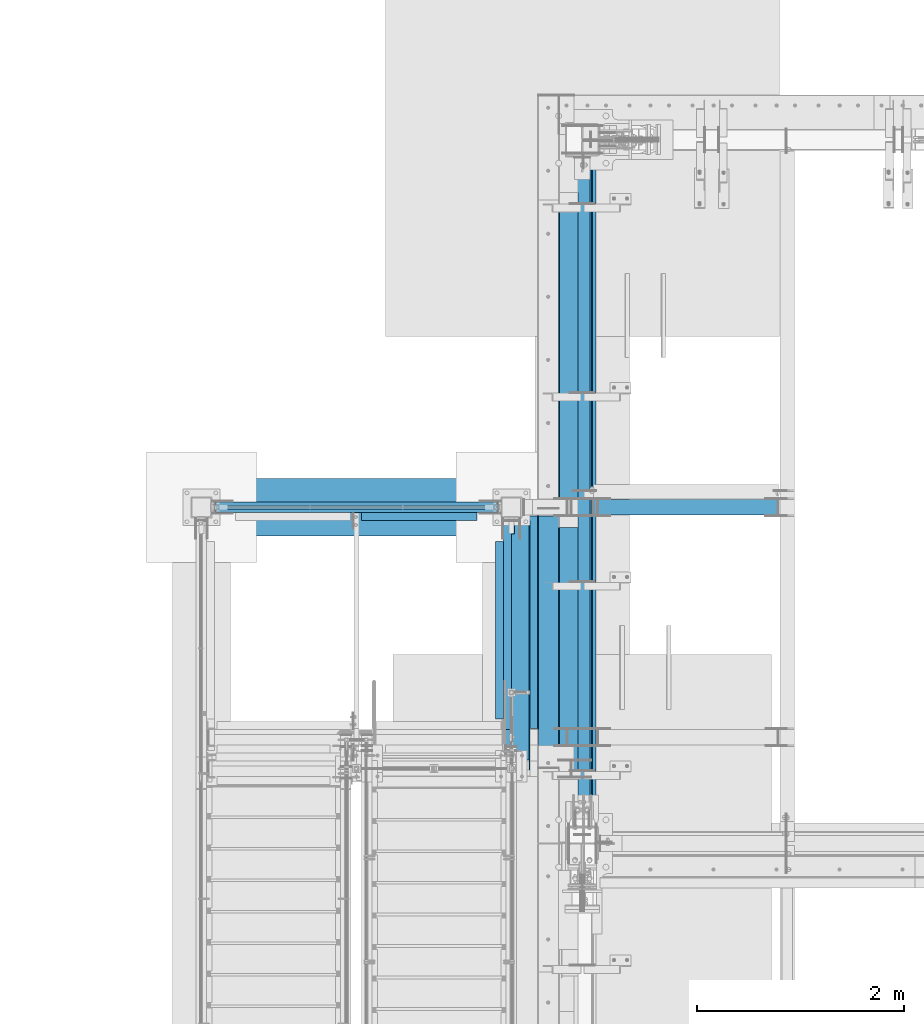
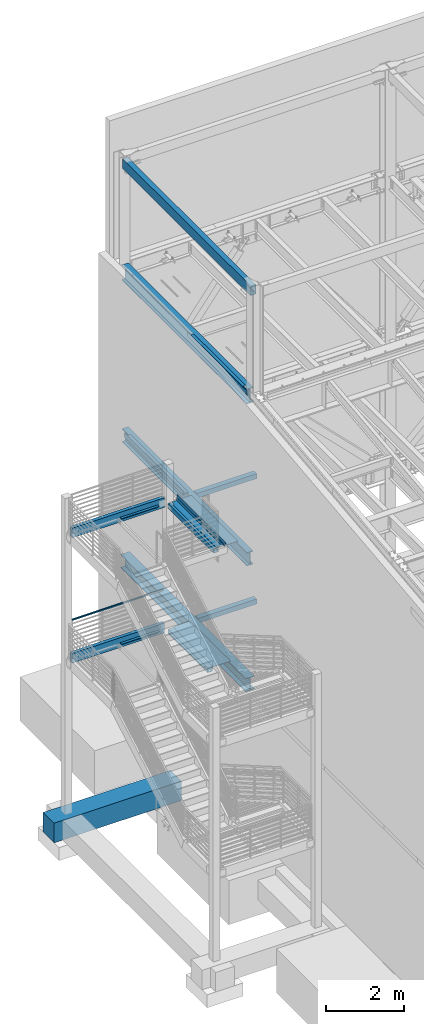
# One storey, part 765 of 1179: 20 beams, 12 elements without a shape of their own.
"""IFC2X3 building model written with IfcOpenShell, lengths in millimetres."""

from ifc_helpers import new_model, si_unit, frame, origin_with_axes, place, context, subcontext, project, spatial, faceted_brep, material, type_object, element, aggregate, save


model = new_model("IFC2X3")

# Units and contexts
model_context = context("Model", 3, precision=1e-05, world=origin_with_axes())
body_context = subcontext(model_context, "Body", "Model", "MODEL_VIEW")
ifc_project = project(units=[si_unit("LENGTHUNIT", "METRE", prefix="MILLI"), si_unit("AREAUNIT", "SQUARE_METRE"), si_unit("VOLUMEUNIT", "CUBIC_METRE"), si_unit("MASSUNIT", "GRAM", prefix="KILO"), si_unit("TIMEUNIT", "SECOND"), si_unit("PLANEANGLEUNIT", "RADIAN"), si_unit("SOLIDANGLEUNIT", "STERADIAN"), si_unit("THERMODYNAMICTEMPERATUREUNIT", "DEGREE_CELSIUS"), si_unit("LUMINOUSINTENSITYUNIT", "LUMEN")], contexts=[model_context])

# Site, building, storey
site_placement = place(None, origin_with_axes())
site = spatial("IfcSite", under=ifc_project, at=site_placement, CompositionType="ELEMENT")
building_placement = place(site_placement, origin_with_axes())
building = spatial("IfcBuilding", under=site, at=building_placement, Name="Undefined", CompositionType="ELEMENT")
storey_placement = place(building_placement, origin_with_axes())
storey = spatial("IfcBuildingStorey", under=building, at=storey_placement, Name="Undefined", CompositionType="ELEMENT", Elevation=0.0)

# Assembly, beam
assembly_1_placement = place(storey_placement, origin_with_axes())
assembly_1 = element("IfcElementAssembly", 1, at=assembly_1_placement, inside=storey, Name="GUARDRAIL", AssemblyPlace="NOTDEFINED", PredefinedType="RIGID_FRAME")
ifc_material_1 = material()
beam_type_1 = type_object("IfcBeamType", Name="HSS1-1/2X1-1/2X1/4", PredefinedType="NOTDEFINED")
beam_1_placement = place(assembly_1_placement, frame((-3098.8, 37642.8, 5302.3029190421), z_axis=(0.0, 0.0, 1.0), x_axis=(1.0, 0.0, 0.0)))
beam_1 = element("IfcBeam", 2, at=beam_1_placement, type_object=beam_type_1, material=ifc_material_1, Name="GUARDRAIL", ObjectType="HSS1-1/2X1-1/2X1/4", context=body_context, shape_type="Brep", body=[
    faceted_brep([(12.6999993300014, 12.6999993299978, -12.6999993299996), (12.6999993300014, -12.6999993299978, -12.6999993299996), (2679.70000067, -12.6999993299978, -12.6999993299996), (2679.70000067, 12.6999993299978, -12.6999993299996), (-12.6999993299983, -12.6999993299978, 12.6999993299996), (2705.09999933, -12.6999993299978, 12.6999993299996), (-12.6999993299983, 12.6999993299978, 12.6999993299996), (2705.09999933, 12.6999993299978, 12.6999993299996), (19.0499999999993, 19.0499992349996, -19.0499992350015), (-19.0499992350015, 19.0499992350015, 19.0499992349996), (2711.449999235, 19.0499992350015, 19.0499992349996), (2673.350000765, 19.0499992350015, -19.0499992349996), (-19.0499992350015, -19.0499992350015, 19.0499992349996), (2711.449999235, -19.0499992350015, 19.0499992349996), (19.0499999999993, -19.0499992349996, -19.0499992350015), (2673.350000765, -19.0499992350015, -19.0499992349996)], [[[0, 1, 2, 3]], [[1, 4, 5, 2]], [[4, 6, 7, 5]], [[6, 0, 3, 7]], [[8, 9, 10, 11]], [[9, 12, 13, 10]], [[12, 14, 15, 13]], [[14, 8, 11, 15]], [[13, 15, 11, 10], [5, 7, 3, 2]], [[14, 12, 9, 8], [6, 4, 1, 0]]]),
])
aggregate(assembly_1, [beam_1])

assembly_2_placement = place(storey_placement, origin_with_axes())
assembly_2 = element("IfcElementAssembly", 3, at=assembly_2_placement, inside=storey, Name="BEAM", AssemblyPlace="NOTDEFINED", PredefinedType="RIGID_FRAME")
ifc_material_2 = material(Name="STEEL/A36")
beam_type_2 = type_object("IfcBeamType", Name="L3X3X1/4", PredefinedType="NOTDEFINED")
beam_2_placement = place(assembly_2_placement, frame((-368.3, 35598.1000000027, 4095.75), z_axis=(0.0, 0.0, -1.0), x_axis=(0.0, 1.0, 0.0)))
beam_2 = element("IfcBeam", 4, at=beam_2_placement, type_object=beam_type_2, material=ifc_material_2, Name="ANGLE", ObjectType="L3X3X1/4", context=body_context, shape_type="Brep", body=[
    faceted_brep([(0.0, 38.0999999999985, -38.0999999999999), (0.0, 38.0999999999985, 38.0999999999999), (1714.49999999727, 38.1, 38.0999999999999), (1714.49999999727, 38.1, -38.1000000000004), (0.0, 31.75, 38.1000000000004), (1714.49999999727, 31.75, 38.0999999999999), (0.0, 31.75, -31.75), (1714.49999999727, 31.75, -31.75), (0.0, -38.0999999999985, -31.75), (1714.49999999727, -38.1, -31.75), (0.0, -38.0999999999985, -38.0999999999999), (1714.49999999727, -38.1, -38.1000000000004)], [[[0, 1, 2, 3]], [[1, 4, 5, 2]], [[4, 6, 7, 5]], [[6, 8, 9, 7]], [[8, 10, 11, 9]], [[10, 0, 3, 11]], [[5, 7, 9, 11, 3, 2]], [[10, 8, 6, 4, 1, 0]]]),
])

assembly_3_placement = place(storey_placement, origin_with_axes())
assembly_3 = element("IfcElementAssembly", 5, at=assembly_3_placement, inside=storey, Name="BEAM", AssemblyPlace="NOTDEFINED", PredefinedType="RIGID_FRAME")
beam_3_placement = place(assembly_3_placement, frame((-1703.3875, 37553.9, 8007.35), z_axis=(0.0, -1.0, 0.0), x_axis=(1.0, 0.0, 0.0)))
beam_3 = element("IfcBeam", 6, at=beam_3_placement, type_object=beam_type_2, material=ifc_material_2, Name="ANGLE", ObjectType="L3X3X1/4", context=body_context, shape_type="Brep", body=[
    faceted_brep([(0.0, 38.0999999999985, -38.0999999999999), (0.0, 38.0999999999985, 38.0999999999999), (1119.1875, 38.1000000000004, 38.0999999999985), (1119.1875, 38.1000000000004, -38.0999999999985), (0.0, 31.75, 38.1000000000004), (1119.1875, 31.75, 38.0999999999985), (0.0, 31.75, -31.75), (1119.1875, 31.75, -31.75), (0.0, -38.0999999999985, -31.75), (1119.1875, -38.1000000000004, -31.75), (0.0, -38.0999999999985, -38.0999999999999), (1119.1875, -38.1000000000004, -38.0999999999985)], [[[0, 1, 2, 3]], [[1, 4, 5, 2]], [[4, 6, 7, 5]], [[6, 8, 9, 7]], [[8, 10, 11, 9]], [[10, 0, 3, 11]], [[5, 7, 9, 11, 3, 2]], [[10, 8, 6, 4, 1, 0]]]),
])

assembly_4_placement = place(storey_placement, origin_with_axes())
assembly_4 = element("IfcElementAssembly", 7, at=assembly_4_placement, inside=storey, Name="BEAM", AssemblyPlace="NOTDEFINED", PredefinedType="RIGID_FRAME")
beam_4_placement = place(assembly_4_placement, frame((-1703.3875, 37553.9, 4095.75), z_axis=(0.0, -1.0, 0.0), x_axis=(1.0, 0.0, 0.0)))
beam_4 = element("IfcBeam", 8, at=beam_4_placement, type_object=beam_type_2, material=ifc_material_2, Name="ANGLE", ObjectType="L3X3X1/4", context=body_context, shape_type="Brep", body=[
    faceted_brep([(0.0, 38.0999999999985, -38.0999999999999), (0.0, 38.0999999999985, 38.0999999999999), (1119.1875, 38.1000000000004, 38.0999999999985), (1119.1875, 38.1000000000004, -38.0999999999985), (0.0, 31.75, 38.1000000000004), (1119.1875, 31.75, 38.0999999999985), (0.0, 31.75, -31.75), (1119.1875, 31.75, -31.75), (0.0, -38.0999999999985, -31.75), (1119.1875, -38.1000000000004, -31.75), (0.0, -38.0999999999985, -38.0999999999999), (1119.1875, -38.1000000000004, -38.0999999999985)], [[[0, 1, 2, 3]], [[1, 4, 5, 2]], [[4, 6, 7, 5]], [[6, 8, 9, 7]], [[8, 10, 11, 9]], [[10, 0, 3, 11]], [[5, 7, 9, 11, 3, 2]], [[10, 8, 6, 4, 1, 0]]]),
])

# Assembly, beams
assembly_5_placement = place(storey_placement, origin_with_axes())
assembly_5 = element("IfcElementAssembly", 9, at=assembly_5_placement, inside=storey, Name="BEAM", AssemblyPlace="NOTDEFINED", PredefinedType="RIGID_FRAME")
beam_type_3 = type_object("IfcBeamType", PredefinedType="NOTDEFINED")
beam_5_placement = place(assembly_5_placement, frame((-253.999999864318, 36283.9, 8048.625), z_axis=(0.0, -1.0, 0.0), x_axis=(1.0, 0.0, 0.0)))
beam_5 = element("IfcBeam", 10, at=beam_5_placement, type_object=beam_type_3, material=ifc_material_2, Name="BENT_PLATE", context=body_context, shape_type="Brep", body=[
    faceted_brep([(31.7564898521653, -3.17500001032931, 400.049998754243), (31.7564896362676, 3.17499998967014, 400.049998754243), (1.67423763741681e-09, 3.17500000000018, 400.049998786097), (-3.93498567063943e-10, -3.17500000000018, 400.049998786097), (31.7500015814076, -3.17500001032658, 463.550000031202), (31.75000136551, 3.17499998967287, 463.550000031202), (-2.91834112431388e-10, -3.17500000000018, 463.550000063056), (1.77587367033993e-09, 3.17500000000018, 463.550000063056), (177.799996443215, 98.4250061614148, 1231.89999999887), (171.449996443215, 98.4250059455244, 1231.8999999989), (171.449998064127, 50.8000029449431, 1231.89999999903), (177.799998064017, 50.8000031608453, 1231.89999999845), (177.799996439302, 98.4250061544117, -1231.90000000114), (171.449996439302, 98.4250059385222, -1231.9000000011), (171.449999674084, 3.17499994423451, -1231.90000000082), (171.449999684391, 3.17499994423451, 1085.90648254335), (171.449998063687, 50.8000029449431, 1085.90648254341), (177.799999900277, -3.1750000578304, 1085.90648254337), (177.799998063687, 50.8000031608453, 1085.90648254337), (2.77213985100389e-09, 3.17500000000018, 1085.90648254335), (7.04403646523133e-10, -3.17500000000018, 1085.90648254451), (177.79999988997, -3.1750000578304, -1231.90000000085), (31.7500000073997, -3.17500001032658, -1231.90000000015), (31.749999791502, 3.17499998967287, -1231.90000000015), (31.7500000243913, -3.17500001032658, -1098.55000003186), (31.7499998084937, 3.17499998967287, -1098.55000003186), (-2.79243295153719e-09, -3.17500000000018, -1098.55000000001), (-7.24725168765872e-10, 3.17500000000018, -1098.55000000001)], [[[0, 1, 2, 3]], [[4, 5, 1, 0]], [[6, 7, 5, 4]], [[8, 9, 10, 11]], [[8, 12, 13, 9]], [[9, 13, 14, 15, 16, 10]], [[17, 18, 16, 15, 19, 20]], [[11, 10, 16, 18]], [[17, 21, 12, 8, 11, 18]], [[14, 13, 12, 21, 22, 23]], [[24, 25, 23, 22]], [[26, 27, 25, 24]], [[27, 26, 3, 2]], [[19, 15, 14, 23, 25, 27, 2, 1, 5, 7]], [[20, 19, 7, 6]], [[3, 26, 24, 22, 21, 17, 20, 6, 4, 0]]]),
])
beam_type_4 = type_object("IfcBeamType", Name="HSS6X6X3/8", PredefinedType="NOTDEFINED")
beam_6_placement = place(assembly_5_placement, frame((-254.000004637913, 35191.6998363215, 7969.25), z_axis=(0.0, 0.0, 1.0), x_axis=(0.0, 1.0, 0.0)))
beam_6 = element("IfcBeam", 11, at=beam_6_placement, type_object=beam_type_4, material=ifc_material_1, Name="BEAM", ObjectType="HSS6X6X3/8", context=body_context, shape_type="Brep", body=[
    faceted_brep([(0.0, 66.6749999999993, -66.6750000000029), (0.0, -66.6749999999993, -66.6750000000029), (2314.57516367846, -66.6750000000168, -66.6750000000002), (2314.57516367859, 66.6749999999832, -66.6750000000002), (0.0, -66.6749999999993, 66.6750000000029), (2314.57516367846, -66.6750000000168, 66.6750000000002), (0.0, 66.6749999999993, 66.6750000000029), (2314.57516367859, 66.6749999999832, 66.6750000000002), (6.54836185276508e-11, 76.2, -76.1999999999998), (6.54836185276508e-11, 76.2, 76.1999999999998), (2314.57516367859, 76.1999999999831, 76.1999999999998), (2314.57516367859, 76.1999999999831, -76.1999999999998), (-6.54836185276508e-11, -76.2, 76.1999999999998), (2314.57516367846, -76.2000000000168, 76.1999999999998), (-6.54836185276508e-11, -76.2, -76.1999999999998), (2314.57516367846, -76.2000000000168, -76.1999999999998)], [[[0, 1, 2, 3]], [[1, 4, 5, 2]], [[4, 6, 7, 5]], [[6, 0, 3, 7]], [[8, 9, 10, 11]], [[9, 12, 13, 10]], [[12, 14, 15, 13]], [[14, 8, 11, 15]], [[13, 15, 11, 10], [5, 7, 3, 2]], [[14, 12, 9, 8], [6, 4, 1, 0]]]),
])
aggregate(assembly_5, [beam_5, beam_6])

# Assembly, beam
assembly_6_placement = place(storey_placement, origin_with_axes())
assembly_6 = element("IfcElementAssembly", 12, at=assembly_6_placement, inside=storey, Name="BEAM", AssemblyPlace="NOTDEFINED", PredefinedType="RIGID_FRAME")
beam_7_placement = place(assembly_6_placement, frame((534.987500000001, 37642.8, 7937.5), z_axis=(0.0, 0.0, 1.0), x_axis=(1.0, 0.0, 0.0)))
beam_7 = element("IfcBeam", 13, at=beam_7_placement, type_object=beam_type_4, material=ifc_material_1, Name="BEAM", ObjectType="HSS6X6X3/8", context=body_context, shape_type="Brep", body=[
    faceted_brep([(9.52499999999998, 66.6750000000029, -66.6750000000002), (9.52499999999998, -66.6750000000029, -66.6750000000002), (1785.9375, -66.6750000000029, -66.6750000000002), (1785.9375, 66.6750000000029, -66.6750000000002), (9.52499999999998, -66.6750000000029, 66.6750000000002), (1785.9375, -66.6750000000029, 66.6750000000002), (9.52499999999998, 66.6750000000029, 66.6750000000002), (1785.9375, 66.6750000000029, 66.6750000000002), (9.52499999999998, 76.1999999999971, -76.1999999999998), (9.52499999999998, 76.1999999999971, 76.1999999999998), (1785.9375, 76.1999999999971, 76.1999999999998), (1785.9375, 76.1999999999971, -76.1999999999998), (9.52499999999998, -76.1999999999971, 76.1999999999998), (1785.9375, -76.1999999999971, 76.1999999999998), (9.52499999999998, -76.1999999999971, -76.1999999999998), (1785.9375, -76.1999999999971, -76.1999999999998)], [[[0, 1, 2, 3]], [[1, 4, 5, 2]], [[4, 6, 7, 5]], [[6, 0, 3, 7]], [[8, 9, 10, 11]], [[9, 12, 13, 10]], [[12, 14, 15, 13]], [[14, 8, 11, 15]], [[13, 15, 11, 10], [5, 7, 3, 2]], [[14, 12, 9, 8], [6, 4, 1, 0]]]),
])
aggregate(assembly_6, [beam_7])

# Beam
beam_8_placement = place(assembly_2_placement, frame((-254.0, 35496.5000000027, 4057.65), z_axis=(0.0, 0.0, 1.0), x_axis=(0.0, 1.0, 0.0)))
beam_8 = element("IfcBeam", 14, at=beam_8_placement, type_object=beam_type_4, material=ifc_material_1, Name="BEAM", ObjectType="HSS6X6X3/8", context=body_context, shape_type="Brep", body=[
    faceted_brep([(0.0, 66.6749999999993, -66.6750000000029), (0.0, -66.6749999999993, -66.6750000000029), (2009.77499999727, -66.675, -66.6750000000002), (2009.77499999727, 66.675, -66.6750000000002), (0.0, -66.6749999999993, 66.6750000000029), (2009.77499999727, -66.675, 66.6750000000002), (0.0, 66.6749999999993, 66.6750000000029), (2009.77499999727, 66.675, 66.6750000000002), (6.54836185276508e-11, 76.2, -76.1999999999998), (6.54836185276508e-11, 76.2, 76.1999999999998), (2009.77499999727, 76.2, 76.1999999999998), (2009.77499999727, 76.2, -76.1999999999998), (-6.54836185276508e-11, -76.2, 76.1999999999998), (2009.77499999727, -76.2, 76.1999999999998), (-6.54836185276508e-11, -76.2, -76.1999999999998), (2009.77499999727, -76.2, -76.1999999999998)], [[[0, 1, 2, 3]], [[1, 4, 5, 2]], [[4, 6, 7, 5]], [[6, 0, 3, 7]], [[8, 9, 10, 11]], [[9, 12, 13, 10]], [[12, 14, 15, 13]], [[14, 8, 11, 15]], [[13, 15, 11, 10], [5, 7, 3, 2]], [[14, 12, 9, 8], [6, 4, 1, 0]]]),
])

aggregate(assembly_2, [beam_2, beam_8])

# Assembly, beam
assembly_7_placement = place(storey_placement, origin_with_axes())
assembly_7 = element("IfcElementAssembly", 15, at=assembly_7_placement, inside=storey, Name="BEAM", AssemblyPlace="NOTDEFINED", PredefinedType="RIGID_FRAME")
beam_9_placement = place(assembly_7_placement, frame((574.674918719381, 37642.8000035719, 4025.9), z_axis=(0.0, 0.0, 1.0), x_axis=(1.0, 0.0, 0.0)))
beam_9 = element("IfcBeam", 16, at=beam_9_placement, type_object=beam_type_4, material=ifc_material_1, Name="BEAM", ObjectType="HSS6X6X3/8", context=body_context, shape_type="Brep", body=[
    faceted_brep([(9.52499999999998, 66.6750000000029, -66.6750000000002), (9.52499999999998, -66.6750000000029, -66.6750000000002), (1746.24983077433, -66.6749999947569, -66.6750000000002), (1746.24983077472, 66.6750000052416, -66.6750000000002), (9.52499999999998, -66.6750000000029, 66.6750000000002), (1746.24983077433, -66.6749999947569, 66.6750000000002), (9.52499999999998, 66.6750000000029, 66.6750000000002), (1746.24983077472, 66.6750000052416, 66.6750000000002), (9.52499999999998, 76.1999999999971, -76.1999999999998), (9.52499999999998, 76.1999999999971, 76.1999999999998), (1746.24983077475, 76.2000000052431, 76.1999999999998), (1746.24983077475, 76.2000000052431, -76.1999999999998), (9.52499999999998, -76.1999999999971, 76.1999999999998), (1746.2498307743, -76.1999999947584, 76.1999999999998), (9.52499999999998, -76.1999999999971, -76.1999999999998), (1746.2498307743, -76.1999999947584, -76.1999999999998)], [[[0, 1, 2, 3]], [[1, 4, 5, 2]], [[4, 6, 7, 5]], [[6, 0, 3, 7]], [[8, 9, 10, 11]], [[9, 12, 13, 10]], [[12, 14, 15, 13]], [[14, 8, 11, 15]], [[13, 15, 11, 10], [5, 7, 3, 2]], [[14, 12, 9, 8], [6, 4, 1, 0]]]),
])
aggregate(assembly_7, [beam_9])

assembly_8_placement = place(storey_placement, origin_with_axes())
assembly_8 = element("IfcElementAssembly", 17, at=assembly_8_placement, inside=storey, Name="BEAM", AssemblyPlace="NOTDEFINED", PredefinedType="RIGID_FRAME")
beam_type_5 = type_object("IfcBeamType", PredefinedType="NOTDEFINED")
beam_10_placement = place(assembly_8_placement, frame((388.937000000003, 35921.9848191647, 13122.275), z_axis=(0.0, -1.0, 0.0), x_axis=(-1.0, 0.0, 0.0)))
beam_10 = element("IfcBeam", 18, at=beam_10_placement, type_object=beam_type_5, material=ifc_material_2, Name="BENT_PLATE", context=body_context, shape_type="Brep", body=[
    faceted_brep([(120.66126457017, -3.17499999999927, 1123.98481918825), (120.66126457017, 3.17499999999927, 1123.98481918825), (0.0, 3.17499999999927, 1123.98481916045), (0.0, -3.17499999999927, 1123.98481916045), (120.650112547347, -3.17499999999927, 1523.99999996131), (120.650112547347, 3.17499999999927, 1524.0), (179.387000000001, -3.17499999999927, -1524.0), (0.0, -3.17499999999927, -1524.0), (0.0, 3.17499999999927, -1524.0), (185.737000000001, 3.17499999999927, -1524.0), (185.737000000001, -130.175000000001, -1524.0), (179.387000000001, -130.175000000001, -1524.0), (185.737000000001, 3.17499999999927, 1524.0), (185.737000000001, -130.175000000001, 1524.0), (179.387000000001, -130.175000000001, 1524.0), (179.387000000001, -3.17499999999927, 1524.0)], [[[0, 1, 2, 3]], [[4, 5, 1, 0]], [[6, 7, 8, 9, 10, 11]], [[9, 12, 13, 10]], [[14, 11, 10, 13]], [[15, 6, 11, 14]], [[3, 7, 6, 15, 4, 0]], [[8, 7, 3, 2]], [[12, 9, 8, 2, 1, 5]], [[15, 14, 13, 12, 5, 4]]]),
])

# Beam
beam_type_6 = type_object("IfcBeamType", Name="HSS12X4X3/8", PredefinedType="NOTDEFINED")
beam_11_placement = place(assembly_3_placement, frame((-3251.2, 37642.8, 8045.45), z_axis=(0.0, 0.0, 1.0), x_axis=(1.0, 0.0, 0.0)))
beam_11 = element("IfcBeam", 19, at=beam_11_placement, type_object=beam_type_6, material=ifc_material_1, Name="BEAM", ObjectType="HSS12X4X3/8", context=body_context, shape_type="Brep", body=[
    faceted_brep([(136.525, 41.2750000000015, -142.875), (136.525, -41.2750000000015, -142.875), (2860.675, -41.2750000000015, -142.875), (2860.675, 41.2750000000015, -142.875), (136.525, -41.2750000000015, 142.875), (2860.675, -41.2750000000015, 142.875), (136.525, 41.2750000000015, 142.875), (2860.675, 41.2750000000015, 142.875), (136.525, 50.7999999999993, -152.4), (136.525, 50.7999999999993, 152.4), (2860.675, 50.7999999999993, 152.4), (2860.675, 50.7999999999993, -152.4), (136.525, -50.7999999999993, 152.4), (2860.675, -50.7999999999993, 152.4), (136.525, -50.7999999999993, -152.4), (2860.675, -50.7999999999993, -152.4)], [[[0, 1, 2, 3]], [[1, 4, 5, 2]], [[4, 6, 7, 5]], [[6, 0, 3, 7]], [[8, 9, 10, 11]], [[9, 12, 13, 10]], [[12, 14, 15, 13]], [[14, 8, 11, 15]], [[13, 15, 11, 10], [5, 7, 3, 2]], [[14, 12, 9, 8], [6, 4, 1, 0]]]),
])

aggregate(assembly_3, [beam_3, beam_11])

beam_12_placement = place(assembly_4_placement, frame((-3251.2, 37642.8, 4133.85), z_axis=(0.0, 0.0, 1.0), x_axis=(1.0, 0.0, 0.0)))
beam_12 = element("IfcBeam", 20, at=beam_12_placement, type_object=beam_type_6, material=ifc_material_1, Name="BEAM", ObjectType="HSS12X4X3/8", context=body_context, shape_type="Brep", body=[
    faceted_brep([(136.525, 41.2750000000015, -142.875), (136.525, -41.2750000000015, -142.875), (2860.675, -41.2750000000015, -142.875), (2860.675, 41.2750000000015, -142.875), (136.525, -41.2750000000015, 142.875), (2860.675, -41.2750000000015, 142.875), (136.525, 41.2750000000015, 142.875), (2860.675, 41.2750000000015, 142.875), (136.525, 50.7999999999993, -152.4), (136.525, 50.7999999999993, 152.4), (2860.675, 50.7999999999993, 152.4), (2860.675, 50.7999999999993, -152.4), (136.525, -50.7999999999993, 152.4), (2860.675, -50.7999999999993, 152.4), (136.525, -50.7999999999993, -152.4), (2860.675, -50.7999999999993, -152.4)], [[[0, 1, 2, 3]], [[1, 4, 5, 2]], [[4, 6, 7, 5]], [[6, 0, 3, 7]], [[8, 9, 10, 11]], [[9, 12, 13, 10]], [[12, 14, 15, 13]], [[14, 8, 11, 15]], [[13, 15, 11, 10], [5, 7, 3, 2]], [[14, 12, 9, 8], [6, 4, 1, 0]]]),
])

aggregate(assembly_4, [beam_4, beam_12])

# Assembly, beam
assembly_9_placement = place(storey_placement, origin_with_axes())
assembly_9 = element("IfcElementAssembly", 21, at=assembly_9_placement, inside=storey, Name="BEAM", AssemblyPlace="NOTDEFINED", PredefinedType="RIGID_FRAME")
beam_type_7 = type_object("IfcBeamType", PredefinedType="NOTDEFINED")
beam_13_placement = place(assembly_9_placement, frame((352.424988126625, 36531.5499981831, 4105.27499857995), z_axis=(0.0, -1.0, 0.0), x_axis=(-1.0, 0.0, 0.0)))
beam_13 = element("IfcBeam", 22, at=beam_13_placement, type_object=beam_type_7, material=ifc_material_2, Name="BENT_PLATE", context=body_context, shape_type="Brep", body=[
    faceted_brep([(498.474988126625, -3.17500000000109, -1028.7), (498.474988126625, 3.17499999999927, -1028.7), (498.474988126625, 3.17499999999927, -1003.30000090903), (498.474988126625, -3.17500000000109, -1003.30000090903), (512.762488126622, 3.17499999999927, -1003.30000090905), (512.762488126622, -3.17500000000109, -1003.30000090905), (512.762488126629, 3.17499999999927, -800.100000909042), (512.762488126629, -3.17500000000109, -800.100000909042), (530.224987792975, -3.17500000000109, -800.100000909042), (523.874987529047, 3.17499999999927, -800.100000909042), (523.874987792969, 47.6249953542415, -800.100000909042), (530.224987792968, 47.6249953165384, -800.100000909042), (0.0, -3.17500000000018, -1028.7), (0.0, -3.17500000000018, 1028.7), (0.0, 3.17500000000018, 1028.7), (0.0, 3.17500000000018, -1028.7), (523.874987529047, 3.17499999999927, 1028.7), (530.224987491344, -3.17500000000109, 1028.7), (530.224987792968, 47.6249953165384, 1028.7), (523.874987792969, 47.6249953542415, 1028.7)], [[[0, 1, 2, 3]], [[3, 2, 4, 5]], [[5, 4, 6, 7]], [[8, 7, 6, 9, 10, 11]], [[12, 13, 14, 15]], [[16, 14, 13, 17, 18, 19]], [[18, 17, 8, 11]], [[19, 18, 11, 10]], [[16, 19, 10, 9]], [[4, 2, 1, 15, 14, 16, 9, 6]], [[12, 15, 1, 0]], [[17, 13, 12, 0, 3, 5, 7, 8]]]),
])

# Assembly, beams
assembly_10_placement = place(storey_placement, origin_with_axes())
assembly_10 = element("IfcElementAssembly", 23, at=assembly_10_placement, inside=storey, Name="BEAM", AssemblyPlace="NOTDEFINED", PredefinedType="RIGID_FRAME")
beam_type_8 = type_object("IfcBeamType", PredefinedType="NOTDEFINED")
beam_14_placement = place(assembly_10_placement, frame((392.112501104944, 36375.9749996743, 8016.87499852424), z_axis=(0.0, 1.0, 0.0), x_axis=(-1.0, 0.0, 0.0)))
beam_14 = element("IfcBeam", 24, at=beam_14_placement, type_object=beam_type_8, material=ifc_material_2, Name="BENT_PLATE", context=body_context, shape_type="Brep", body=[
    faceted_brep([(392.112501040346, -3.17499982697063, 1184.27500034528), (392.112500428191, 34.9250077518063, 1184.2750003385), (385.762500428423, 34.925007650204, 1184.27500033854), (385.762500938755, 3.17500016787562, 1184.27500010152), (385.762501235576, -3.17499983212474, 1184.27500010152), (392.112500429548, 34.9250022055585, 1257.29999999794), (385.762500429763, 34.9250021039579, 1257.29999999799), (-5.25744781043613e-10, -3.17499999999927, -1177.98148229237), (-3.28799387716572e-09, 3.17500000000109, -1177.98148229237), (385.762500923642, 3.17500016787562, -1177.98148285491), (385.762501034468, -3.17499983212474, -1177.98148285491), (392.112501025233, -3.17499974965267, -1177.98148285756), (385.762499758165, 76.2000040579551, -1177.98148286401), (392.112499758165, 76.2000041595566, -1177.98148286405), (385.762499758298, 76.2000100814748, -1257.30000000221), (392.11249975842, 76.2000101830772, -1257.30000000225), (385.762498897332, 130.175012362386, -1257.30000000247), (392.112498897332, 130.175012463978, -1257.30000000251), (385.762498901265, 130.175012374044, 1184.27500010152), (385.762498901383, 130.175012374393, 1257.29999999753), (392.112498901383, 130.175012475986, 1257.29999999749), (385.76249889746, 130.175012362764, -1177.98148285491), (3.2981688491418e-09, -3.17499999999927, 1184.27500032723), (5.35862909600837e-10, 3.17500000000109, 1184.27500032723)], [[[0, 1, 2, 3, 4]], [[5, 6, 2, 1]], [[7, 8, 9, 10]], [[11, 10, 9, 12, 13]], [[13, 12, 14, 15]], [[16, 17, 15, 14]], [[18, 19, 20, 17, 16, 21]], [[0, 11, 13, 15, 17, 20, 5, 1]], [[22, 7, 10, 11, 0, 4]], [[8, 7, 22, 23]], [[4, 3, 23, 22]], [[9, 8, 23, 3]], [[19, 18, 21, 16, 14, 12, 9, 3, 2, 6]], [[20, 19, 6, 5]]]),
])
beam_type_9 = type_object("IfcBeamType", PredefinedType="NOTDEFINED")
beam_15_placement = place(assembly_10_placement, frame((392.112502801265, 39163.8000448903, 8016.875), z_axis=(0.0, 1.0, 0.0), x_axis=(-1.0, 0.0, 0.0)))
beam_15 = element("IfcBeam", 25, at=beam_15_placement, type_object=beam_type_9, material=ifc_material_2, Name="BENT_PLATE", context=body_context, shape_type="Brep", body=[
    faceted_brep([(188.912477849342, 34.925006045265, -1444.62500081179), (182.562477849342, 34.9250058420639, -1444.6250008118), (182.562477849625, 34.9250037780685, -1523.99999999974), (188.912477849593, 34.9250039812705, -1523.99999999973), (188.912479068929, -3.17500005796319, -1444.62500080771), (182.562483343217, -3.1750000560769, -1444.62500081108), (182.562478865735, 3.17499994392347, -1444.62500081108), (63.4999998487492, -3.17500407120497, -1444.62500080793), (-3.9182168620755e-10, -3.17499999999927, -1444.62500080805), (1.56092028191779e-09, 3.17500000000109, -1444.62500080829), (63.4999996455513, 3.17499998049607, -1444.62500080545), (6.00266503170133e-10, -3.17499999922438, 1524.00000000052), (6.00266503170133e-10, 3.17500000077416, 1524.00000000052), (182.562478862709, 3.17499994392347, 1524.00000000025), (182.562474801051, 130.175012093318, -1523.99999999968), (188.912474801051, 130.175012296513, -1523.99999999967), (182.562474799745, 130.175012091413, 1524.00000000032), (182.562474801017, 130.175012093268, -1444.62500081108), (188.912474799745, 130.175012294607, 1524.00000000033), (188.912479065902, -3.17500005802776, 1524.00000000025)], [[[0, 1, 2, 3]], [[4, 5, 6, 1, 0]], [[7, 8, 9, 10]], [[11, 12, 9, 8]], [[7, 10, 6, 5]], [[12, 13, 6, 10, 9]], [[14, 15, 3, 2]], [[13, 16, 17, 14, 2, 1, 6]], [[16, 18, 15, 14, 17]], [[13, 12, 11, 19, 18, 16]], [[3, 15, 18, 19, 4, 0]], [[19, 11, 8, 7, 5, 4]]]),
])

# Assembly, beam
assembly_11_placement = place(storey_placement, origin_with_axes())
assembly_11 = element("IfcElementAssembly", 26, at=assembly_11_placement, inside=storey, Name="BEAM", AssemblyPlace="NOTDEFINED", PredefinedType="RIGID_FRAME")
beam_type_10 = type_object("IfcBeamType", Name="HSS12X6X3/8", PredefinedType="NOTDEFINED")
beam_16_placement = place(assembly_11_placement, frame((431.8, 34469.3875000406, 16275.05), z_axis=(0.0, 0.0, 1.0), x_axis=(0.0, 1.0, 0.0)))
beam_16 = element("IfcBeam", 27, at=beam_16_placement, type_object=beam_type_10, material=ifc_material_1, Name="BEAM", ObjectType="HSS12X6X3/8", context=body_context, shape_type="Brep", body=[
    faceted_brep([(9.52500000000146, 66.675, -142.875), (9.52500000000146, -66.675, -142.875), (6554.78749995939, -66.675, -142.875), (6554.78749995939, 66.675, -142.875), (9.52500000000146, -66.675, 142.875000000002), (6554.78749995939, -66.675, 142.875000000002), (9.52500000000146, 66.675, 142.875000000002), (6554.78749995939, 66.675, 142.875000000002), (9.52500000000146, 76.2, -152.4), (9.52500000000146, 76.2, 152.4), (6554.78749995939, 76.2, 152.4), (6554.78749995939, 76.2, -152.4), (9.52500000000146, -76.2, 152.4), (6554.78749995939, -76.2, 152.4), (9.52500000000146, -76.2, -152.4), (6554.78749995939, -76.2, -152.4)], [[[0, 1, 2, 3]], [[1, 4, 5, 2]], [[4, 6, 7, 5]], [[6, 0, 3, 7]], [[8, 9, 10, 11]], [[9, 12, 13, 10]], [[12, 14, 15, 13]], [[14, 8, 11, 15]], [[13, 15, 11, 10], [5, 7, 3, 2]], [[14, 12, 9, 8], [6, 4, 1, 0]]]),
])
aggregate(assembly_11, [beam_16])

# Beam
ifc_material_3 = material(Name="STEEL/A992")
beam_type_11 = type_object("IfcBeamType", Name="W16X57", PredefinedType="NOTDEFINED")
beam_17_placement = place(assembly_10_placement, frame((431.800000000001, 34391.6, 7805.7375), z_axis=(0.0, 0.0, 1.0), x_axis=(0.0, 1.0, 0.0)))
beam_17 = element("IfcBeam", 28, at=beam_17_placement, type_object=beam_type_11, material=ifc_material_3, Name="BEAM", ObjectType="W16X57", context=body_context, shape_type="Brep", body=[
    faceted_brep([(247.649999999994, -90.4875, -207.9625), (247.649999999994, 90.4875, -207.9625), (6637.33750000001, 90.4875, -207.9625), (6637.33750000001, -90.4875, -207.9625), (247.649999999994, -90.4875, -190.5), (247.649999999994, -5.55624999999998, -190.5), (247.649999999994, -5.55624999999998, -148.37749982202), (247.649999999994, -5.55624999999998, 157.902500177689), (247.649999999994, -5.55624999999998, 190.5), (247.649999999994, -90.4875, 190.5), (247.649999999994, -90.4875, 207.9625), (247.649999999994, 90.4875, 207.9625), (247.649999999994, 90.4875, 190.5), (247.649999999994, 5.55624999999998, 190.5), (247.649999999994, 5.55624999999998, -190.5), (247.649999999994, 90.4875, -190.5), (6637.33750000001, -90.4875, -190.5), (6637.33750000001, -5.55624999999998, -190.5), (6637.33750000001, -5.55624999999998, 190.5), (6637.33750000001, -90.4875, 190.5), (6637.33750000001, -90.4875, 207.9625), (6637.33750000001, 90.4875, 207.9625), (6637.33750000001, 90.4875, 190.5), (6637.33750000001, 5.55624999999998, 190.5), (6637.33750000001, 5.55624999999998, -190.5), (6637.33750000001, 90.4875, -190.5)], [[[0, 1, 2, 3]], [[0, 4, 5, 6, 7, 8, 9, 10, 11, 12, 13, 14, 15, 1]], [[5, 4, 16, 17]], [[8, 7, 6, 5, 17, 18]], [[9, 8, 18, 19]], [[10, 9, 19, 20]], [[11, 10, 20, 21]], [[12, 11, 21, 22]], [[13, 12, 22, 23]], [[14, 13, 23, 24]], [[15, 14, 24, 25]], [[1, 15, 25, 2]], [[24, 23, 22, 21, 20, 19, 18, 17, 16, 3, 2, 25]], [[4, 0, 3, 16]]]),
])

aggregate(assembly_10, [beam_15, beam_14, beam_17])

beam_type_12 = type_object("IfcBeamType", Name="W18X65", PredefinedType="NOTDEFINED")
beam_18_placement = place(assembly_8_placement, frame((431.8, 34391.6, 12885.7375), z_axis=(0.0, 0.0, 1.0), x_axis=(0.0, 1.0, 0.0)))
beam_18 = element("IfcBeam", 29, at=beam_18_placement, type_object=beam_type_12, material=ifc_material_3, Name="BEAM", ObjectType="W18X65", context=body_context, shape_type="Brep", body=[
    faceted_brep([(247.650000000016, -96.8375000000015, -233.362499999999), (247.650000000016, 96.8375000000015, -233.362499999999), (6637.33750000001, 96.8375, -233.362499999999), (6637.33750000001, -96.8375, -233.362499999999), (247.650000000016, -96.8375000000015, -214.3125), (247.650000000016, -5.55625000000146, -214.3125), (247.650000000001, -5.55624999999998, -122.977499999979), (247.650000000001, -5.55624999999998, 183.302500000127), (247.650000000016, -5.55625000000146, 214.3125), (247.650000000016, -96.8375000000015, 214.3125), (247.650000000016, -96.8375000000015, 233.362499999999), (247.650000000016, 96.8375000000015, 233.362499999999), (247.650000000016, 96.8375000000015, 214.3125), (247.650000000016, 5.55625000000146, 214.3125), (247.650000000016, 5.55625000000146, -214.3125), (247.650000000016, 96.8375000000015, -214.3125), (6637.33750000001, -96.8375, -214.3125), (6637.33750000001, -5.55624999999998, -214.3125), (6637.33750000001, -5.55624999999998, 214.3125), (6637.33750000001, -96.8375, 214.3125), (6637.33750000001, -96.8375, 233.362499999999), (6637.33750000001, 96.8375, 233.362499999999), (6637.33750000001, 96.8375, 214.3125), (6637.33750000001, 5.55624999999998, 214.3125), (6637.33750000001, 5.55624999999998, -214.3125), (6637.33750000001, 96.8375, -214.3125)], [[[0, 1, 2, 3]], [[0, 4, 5, 6, 7, 8, 9, 10, 11, 12, 13, 14, 15, 1]], [[5, 4, 16, 17]], [[8, 7, 6, 5, 17, 18]], [[9, 8, 18, 19]], [[10, 9, 19, 20]], [[11, 10, 20, 21]], [[12, 11, 21, 22]], [[13, 12, 22, 23]], [[14, 13, 23, 24]], [[15, 14, 24, 25]], [[1, 15, 25, 2]], [[24, 23, 22, 21, 20, 19, 18, 17, 16, 3, 2, 25]], [[4, 0, 3, 16]]]),
])

aggregate(assembly_8, [beam_10, beam_18])

beam_type_13 = type_object("IfcBeamType", Name="W16X77", PredefinedType="NOTDEFINED")
beam_19_placement = place(assembly_9_placement, frame((431.8, 34391.6, 3892.55), z_axis=(0.0, 0.0, 1.0), x_axis=(0.0, 1.0, 0.0)))
beam_19 = element("IfcBeam", 30, at=beam_19_placement, type_object=beam_type_13, material=ifc_material_3, Name="BEAM", ObjectType="W16X77", context=body_context, shape_type="Brep", body=[
    faceted_brep([(247.650000000001, -130.174999999999, -209.55), (247.650000000001, 130.174999999999, -209.55), (6637.33750000001, 130.175, -209.55), (6637.33750000001, -130.175, -209.55), (247.650000000001, -130.174999999999, -190.5), (247.649999999994, -5.55624999999998, -190.5), (247.650000000001, -5.55624999999998, -146.789999999991), (247.650000000001, -5.55624999999998, 159.490000000113), (247.649999999994, -5.55624999999998, 190.5), (247.650000000001, -130.174999999999, 190.5), (247.650000000001, -130.174999999999, 209.55), (247.650000000001, 130.174999999999, 209.55), (247.650000000001, 130.174999999999, 190.5), (247.649999999994, 5.55624999999998, 190.5), (247.649999999994, 5.55624999999998, -190.5), (247.650000000001, 130.174999999999, -190.5), (6637.33750000001, -130.175, -190.5), (6637.33750000001, -5.55624999999998, -190.5), (6637.33750000001, -5.55624999999998, 190.5), (6637.33750000001, -130.175, 190.5), (6637.33750000001, -130.175, 209.55), (6637.33750000001, 130.175, 209.55), (6637.33750000001, 130.175, 190.5), (6637.33750000001, 5.55624999999998, 190.5), (6637.33750000001, 5.55624999999998, -190.5), (6637.33750000001, 130.175, -190.5)], [[[0, 1, 2, 3]], [[0, 4, 5, 6, 7, 8, 9, 10, 11, 12, 13, 14, 15, 1]], [[5, 4, 16, 17]], [[8, 7, 6, 5, 17, 18]], [[9, 8, 18, 19]], [[10, 9, 19, 20]], [[11, 10, 20, 21]], [[12, 11, 21, 22]], [[13, 12, 22, 23]], [[14, 13, 23, 24]], [[15, 14, 24, 25]], [[1, 15, 25, 2]], [[24, 23, 22, 21, 20, 19, 18, 17, 16, 3, 2, 25]], [[4, 0, 3, 16]]]),
])

aggregate(assembly_9, [beam_13, beam_19])

# Assembly, beam
assembly_12_placement = place(storey_placement, origin_with_axes())
assembly_12 = element("IfcElementAssembly", 31, at=assembly_12_placement, inside=storey, Name="GRADE_BEAM", AssemblyPlace="NOTDEFINED", PredefinedType="REINFORCEMENT_UNIT")
ifc_material_4 = material(Name="CONCRETE/5000")
beam_type_14 = type_object("IfcBeamType", PredefinedType="NOTDEFINED")
beam_20_placement = place(assembly_12_placement, frame((-3784.6, 37642.8, -939.8), z_axis=(0.0, 0.0, 1.0), x_axis=(1.0, 0.0, 0.0)))
beam_20 = element("IfcBeam", 32, at=beam_20_placement, type_object=beam_type_14, material=ifc_material_4, Name="GRADE_BEAM", context=body_context, shape_type="Brep", body=[
    faceted_brep([(0.0, 279.4, -304.8), (0.0, 279.4, 304.8), (3759.2, 279.400000000001, 304.8), (3759.2, 279.400000000001, -304.8), (0.0, -279.4, 304.8), (3759.2, -279.400000000001, 304.8), (0.0, -279.4, -304.8), (3759.2, -279.400000000001, -304.8)], [[[0, 1, 2, 3]], [[1, 4, 5, 2]], [[4, 6, 7, 5]], [[6, 0, 3, 7]], [[5, 7, 3, 2]], [[6, 4, 1, 0]]]),
])
aggregate(assembly_12, [beam_20])

save(model, "model.ifc")
